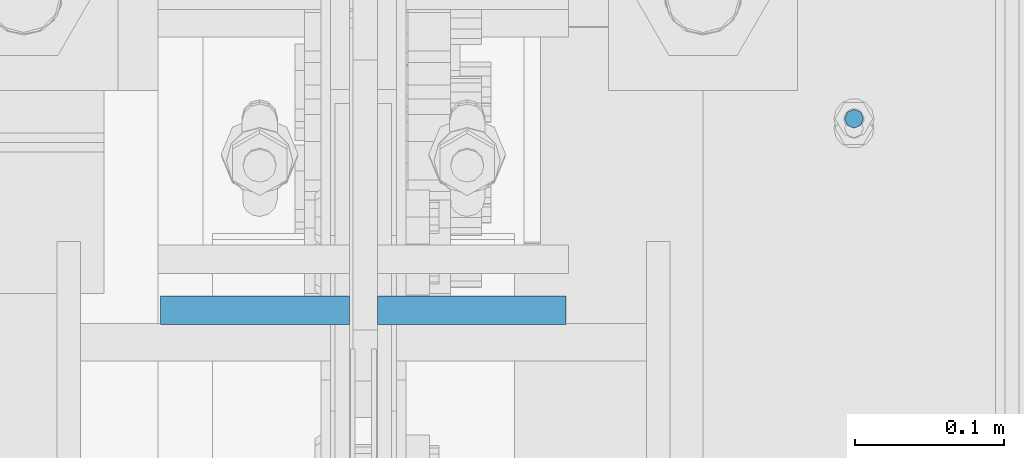
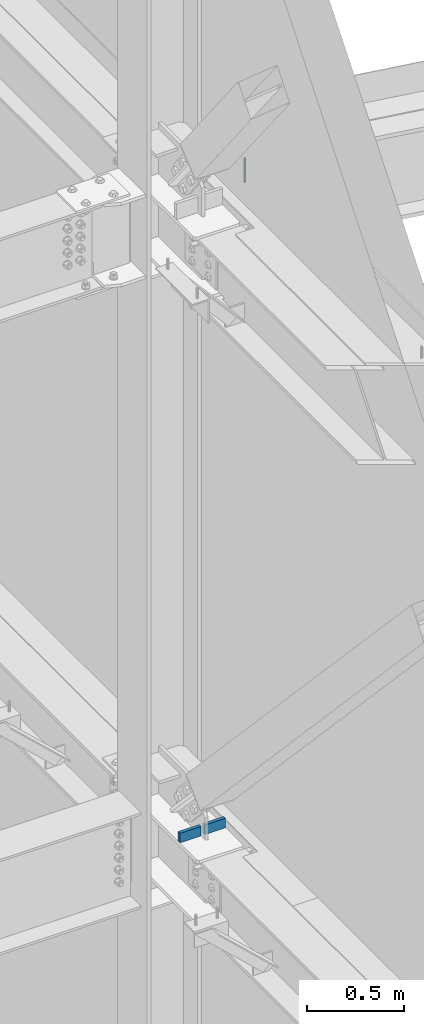
# One storey, part 558 of 1179: 3 columns, 2 elements without a shape of their own.
"""IFC2X3 building model written with IfcOpenShell, lengths in millimetres."""

from ifc_helpers import new_model, si_unit, frame, origin_with_axes, place, context, subcontext, project, spatial, faceted_brep, material, type_object, element, aggregate, save


model = new_model("IFC2X3")

# Units and contexts
model_context = context("Model", 3, precision=1e-05, world=origin_with_axes())
body_context = subcontext(model_context, "Body", "Model", "MODEL_VIEW")
ifc_project = project(units=[si_unit("LENGTHUNIT", "METRE", prefix="MILLI"), si_unit("AREAUNIT", "SQUARE_METRE"), si_unit("VOLUMEUNIT", "CUBIC_METRE"), si_unit("MASSUNIT", "GRAM", prefix="KILO"), si_unit("TIMEUNIT", "SECOND"), si_unit("PLANEANGLEUNIT", "RADIAN"), si_unit("SOLIDANGLEUNIT", "STERADIAN"), si_unit("THERMODYNAMICTEMPERATUREUNIT", "DEGREE_CELSIUS"), si_unit("LUMINOUSINTENSITYUNIT", "LUMEN")], contexts=[model_context])

# Site, building, storey
site_placement = place(None, origin_with_axes())
site = spatial("IfcSite", under=ifc_project, at=site_placement, CompositionType="ELEMENT")
building_placement = place(site_placement, origin_with_axes())
building = spatial("IfcBuilding", under=site, at=building_placement, Name="Undefined", CompositionType="ELEMENT")
storey_placement = place(building_placement, origin_with_axes())
storey = spatial("IfcBuildingStorey", under=building, at=storey_placement, Name="Undefined", CompositionType="ELEMENT", Elevation=0.0)

# Assembly, column
assembly_1_placement = place(storey_placement, origin_with_axes())
assembly_1 = element("IfcElementAssembly", 1, at=assembly_1_placement, inside=storey, Name="BEAM", AssemblyPlace="NOTDEFINED", PredefinedType="RIGID_FRAME")
ifc_material_1 = material(Name="STEEL/A307")
column_type_1 = type_object("IfcColumnType", PredefinedType="NOTDEFINED")
column_1_placement = place(assembly_1_placement, frame((24638.0000051215, 34080.4500001664, 8023.22499553788), z_axis=(0.0, 1.0, 0.0), x_axis=(0.0, 0.0, 1.0)))
column_1 = element("IfcColumn", 2, at=column_1_placement, type_object=column_type_1, material=ifc_material_1, Name="THREADED ROD", context=body_context, shape_type="Brep", body=[
    faceted_brep([(0.0, -6.34999999999854, 0.0), (0.0, -4.49012806053361, -4.49012806053452), (153.987504462122, -4.49012806053361, -4.49012806053361), (153.987504462122, -6.34999999999854, 0.0), (0.0, 0.0, -6.34999999999991), (153.987504462122, 0.0, -6.34999999999854), (0.0, 4.49012806053361, -4.49012806053452), (153.987504462122, 4.49012806053361, -4.49012806053361), (0.0, 6.34999999999854, 0.0), (153.987504462122, 6.34999999999854, 0.0), (0.0, 4.49012806053361, 4.49012806053452), (153.987504462122, 4.49012806053361, 4.49012806053361), (0.0, 0.0, 6.34999999999991), (153.987504462122, 0.0, 6.34999999999854), (0.0, -4.49012806053361, 4.49012806053452), (153.987504462122, -4.49012806053361, 4.49012806053361)], [[[0, 1, 2, 3]], [[1, 4, 5, 2]], [[4, 6, 7, 5]], [[6, 8, 9, 7]], [[8, 10, 11, 9]], [[10, 12, 13, 11]], [[12, 14, 15, 13]], [[14, 0, 3, 15]], [[5, 7, 9, 11, 13, 15, 3, 2]], [[14, 12, 10, 8, 6, 4, 1, 0]]]),
])
aggregate(assembly_1, [column_1])

# Assembly, columns
assembly_2_placement = place(storey_placement, origin_with_axes())
assembly_2 = element("IfcElementAssembly", 3, at=assembly_2_placement, inside=storey, Name="COLUMN", AssemblyPlace="NOTDEFINED", PredefinedType="RIGID_FRAME")
ifc_material_2 = material(Name="STEEL/A572-GR.50")
column_type_2 = type_object("IfcColumnType", PredefinedType="NOTDEFINED")
column_2_placement = place(assembly_2_placement, frame((24234.775, 33951.6419989338, 4102.1), z_axis=(1.0, 0.0, 0.0), x_axis=(0.0, 0.0, 1.0)))
column_2 = element("IfcColumn", 4, at=column_2_placement, type_object=column_type_2, material=ifc_material_2, Name="PLATE", context=body_context, shape_type="Brep", body=[
    faceted_brep([(0.0, 9.52500000000146, -63.5), (0.0, 9.52500000000146, 63.5), (59.8857973215509, 9.52500000000146, 63.5), (59.8857973215509, 9.52500000000146, -63.5), (0.0, -9.52500000000146, 63.5), (59.8857973215509, -9.52500000000146, 63.5), (0.0, -9.52500000000146, -63.5), (59.8857973215509, -9.52500000000146, -63.5)], [[[0, 1, 2, 3]], [[1, 4, 5, 2]], [[4, 6, 7, 5]], [[6, 0, 3, 7]], [[5, 7, 3, 2]], [[6, 4, 1, 0]]]),
])
column_3_placement = place(assembly_2_placement, frame((24380.825, 33951.6419989338, 4102.1), z_axis=(-1.0, 0.0, 0.0), x_axis=(0.0, 0.0, 1.0)))
column_3 = element("IfcColumn", 5, at=column_3_placement, type_object=column_type_2, material=ifc_material_2, Name="PLATE", context=body_context, shape_type="Brep", body=[
    faceted_brep([(0.0, 9.52500000000146, -63.5), (0.0, 9.52500000000146, 63.5), (59.8857973215509, 9.52500000000146, 63.5), (59.8857973215509, 9.52500000000146, -63.5), (0.0, -9.52500000000146, 63.5), (59.8857973215509, -9.52500000000146, 63.5), (0.0, -9.52500000000146, -63.5), (59.8857973215509, -9.52500000000146, -63.5)], [[[0, 1, 2, 3]], [[1, 4, 5, 2]], [[4, 6, 7, 5]], [[6, 0, 3, 7]], [[5, 7, 3, 2]], [[6, 4, 1, 0]]]),
])
aggregate(assembly_2, [column_2, column_3])

save(model, "model.ifc")
